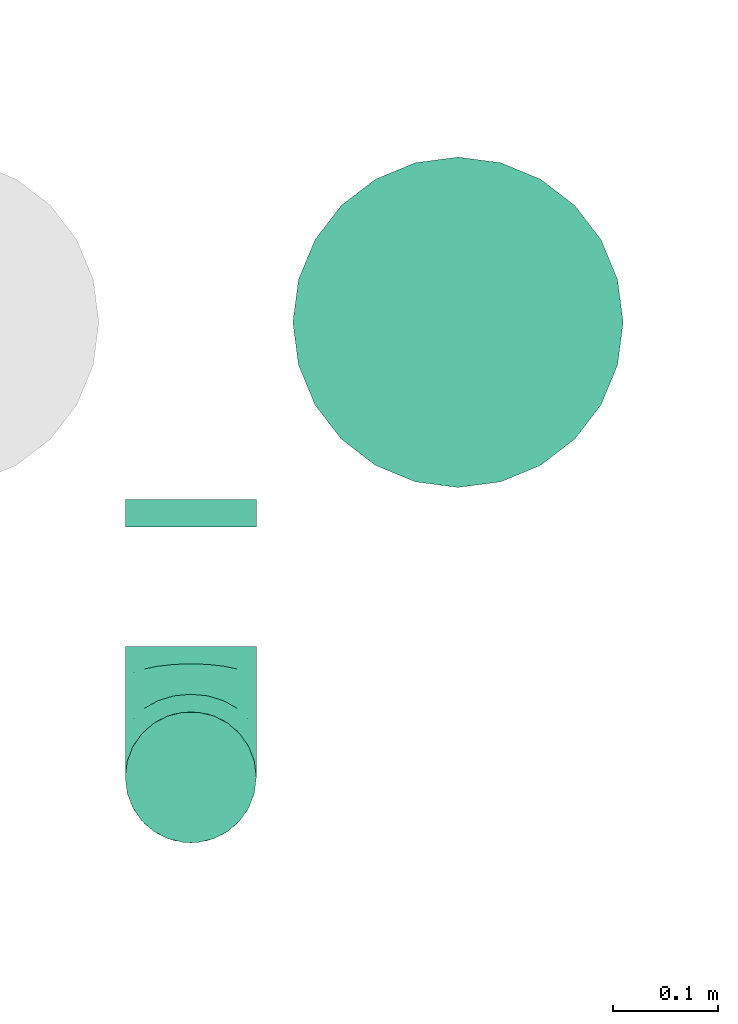
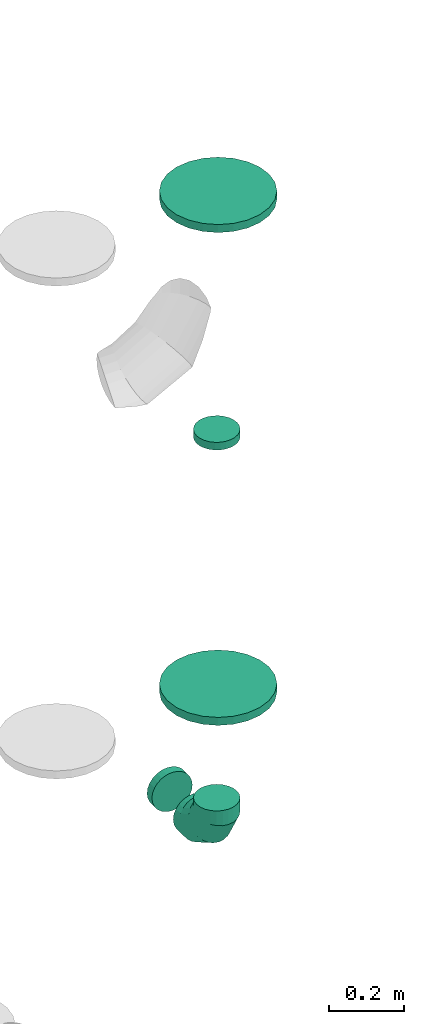
# One storey, part 49 of 59: 5 flow fittings.
"""IFC2X3 building model written with IfcOpenShell, lengths in millimetres."""

from ifc_helpers import new_model, entity, si_unit, converted_unit, derived_unit, direction, frame, origin, origin_2d_with_axis, place, context, subcontext, project, spatial, circle, extrude, faceted_brep, source, transform, mapped, material, type_object, type_shapes, element, save


model = new_model("IFC2X3")

# Units and contexts
model_context = context("Model", 3, precision=0.01, world=origin(), true_north=direction((6.12303176911189e-17, 1.0)))
body_context = subcontext(model_context, "Body", "Model", "MODEL_VIEW")
ifc_project = project(units=[si_unit("LENGTHUNIT", "METRE", prefix="MILLI"), si_unit("AREAUNIT", "SQUARE_METRE"), si_unit("VOLUMEUNIT", "CUBIC_METRE"), converted_unit("PLANEANGLEUNIT", "DEGREE", entity("IfcRatioMeasure", 0.0174532925199433), si_unit("PLANEANGLEUNIT", "RADIAN"), dimensions=[0, 0, 0, 0, 0, 0, 0]), si_unit("MASSUNIT", "GRAM", prefix="KILO"), derived_unit("MASSDENSITYUNIT", [(si_unit("MASSUNIT", "GRAM", prefix="KILO"), 1), (si_unit("LENGTHUNIT", "METRE"), -3)]), derived_unit("MOMENTOFINERTIAUNIT", [(si_unit("LENGTHUNIT", "METRE"), 4)]), si_unit("TIMEUNIT", "SECOND"), si_unit("FREQUENCYUNIT", "HERTZ"), si_unit("THERMODYNAMICTEMPERATUREUNIT", "DEGREE_CELSIUS"), derived_unit("THERMALTRANSMITTANCEUNIT", [(si_unit("MASSUNIT", "GRAM", prefix="KILO"), 1), (si_unit("THERMODYNAMICTEMPERATUREUNIT", "KELVIN"), -1), (si_unit("TIMEUNIT", "SECOND"), -3)]), derived_unit("VOLUMETRICFLOWRATEUNIT", [(si_unit("LENGTHUNIT", "METRE"), 3), (si_unit("TIMEUNIT", "SECOND"), -1)]), derived_unit("MASSFLOWRATEUNIT", [(si_unit("MASSUNIT", "GRAM", prefix="KILO"), 1), (si_unit("TIMEUNIT", "SECOND"), -1)]), derived_unit("ROTATIONALFREQUENCYUNIT", [(si_unit("TIMEUNIT", "SECOND"), -1)]), si_unit("ELECTRICCURRENTUNIT", "AMPERE"), si_unit("ELECTRICVOLTAGEUNIT", "VOLT"), si_unit("POWERUNIT", "WATT"), si_unit("FORCEUNIT", "NEWTON", prefix="KILO"), si_unit("ILLUMINANCEUNIT", "LUX"), si_unit("LUMINOUSFLUXUNIT", "LUMEN"), si_unit("LUMINOUSINTENSITYUNIT", "CANDELA"), derived_unit("USERDEFINED", [(si_unit("MASSUNIT", "GRAM", prefix="KILO"), -1), (si_unit("LENGTHUNIT", "METRE"), -2), (si_unit("TIMEUNIT", "SECOND"), 3), (si_unit("LUMINOUSFLUXUNIT", "LUMEN"), 1)]), derived_unit("LINEARVELOCITYUNIT", [(si_unit("LENGTHUNIT", "METRE"), 1), (si_unit("TIMEUNIT", "SECOND"), -1)]), si_unit("PRESSUREUNIT", "PASCAL"), derived_unit("USERDEFINED", [(si_unit("LENGTHUNIT", "METRE"), -2), (si_unit("MASSUNIT", "GRAM", prefix="KILO"), 1), (si_unit("TIMEUNIT", "SECOND"), -2)]), derived_unit("LINEARFORCEUNIT", [(si_unit("MASSUNIT", "GRAM", prefix="KILO"), 1), (si_unit("LENGTHUNIT", "METRE"), 1), (si_unit("TIMEUNIT", "SECOND"), -2), (si_unit("LENGTHUNIT", "METRE"), -1)]), derived_unit("PLANARFORCEUNIT", [(si_unit("MASSUNIT", "GRAM", prefix="KILO"), 1), (si_unit("LENGTHUNIT", "METRE"), 1), (si_unit("TIMEUNIT", "SECOND"), -2), (si_unit("LENGTHUNIT", "METRE"), -2)])], contexts=[model_context])

# Site, building, storey
site_placement = place(None, origin())
site = spatial("IfcSite", under=ifc_project, at=site_placement, CompositionType="ELEMENT")
building_placement = place(site_placement, origin())
building = spatial("IfcBuilding", under=site, at=building_placement, CompositionType="ELEMENT")
storey_placement = place(building_placement, frame((0.0, 0.0, 28200.0)))
storey = spatial("IfcBuildingStorey", under=building, at=storey_placement, CompositionType="ELEMENT", Elevation=28200.0)

# Flow fittings
ifc_material = material()
duct_fitting_type_1 = type_object("IfcDuctFittingType", PredefinedType="NOTDEFINED", material=ifc_material)
shared_shape_1 = source(origin(), body_context, "Body", "SweptSolid", [
    extrude(circle(Radius=62.4999999999996, at=origin_2d_with_axis()), frame((0.0, 0.0, 0.0), z_axis=(1.0, 0.0, 0.0), x_axis=(0.0, 1.0, 0.0)), (0.0, 0.0, 1.0), 25.0000000000018),
])
type_shapes(duct_fitting_type_1, [shared_shape_1])
flow_fitting_1_placement = place(storey_placement, frame((72718.06, 16207.74, 1705.0), z_axis=(0.0, 1.0, 0.0), x_axis=(0.0, 0.0, 1.0)))
element("IfcFlowFitting", 1, at=flow_fitting_1_placement, inside=storey, type_object=duct_fitting_type_1, material=ifc_material, context=body_context, shape_type="MappedRepresentation", body=[
    mapped(shared_shape_1, transform((0.0, 0.0, 0.0), scale=1.0)),
])
duct_fitting_type_2 = type_object("IfcDuctFittingType", PredefinedType="NOTDEFINED", material=ifc_material)
shared_shape_2 = source(origin(), body_context, "Body", "Brep", [
    faceted_brep([(-125.0, 0.0, -62.5), (-125.0, -16.18, -60.37), (-125.0, -31.25, -54.13), (-125.0, -44.19, -44.19), (-125.0, -54.13, -31.25), (-125.0, -60.37, -16.18), (-125.0, -62.5, 0.0), (-125.0, -60.37, 16.18), (-125.0, -54.13, 31.25), (-125.0, -44.19, 44.19), (-125.0, -31.25, 54.13), (-125.0, -16.18, 60.37), (-125.0, 0.0, 62.5), (-125.0, 16.18, 60.37), (-125.0, 31.25, 54.13), (-125.0, 44.19, 44.19), (-125.0, 54.13, 31.25), (-125.0, 60.37, 16.18), (-125.0, 62.5, 0.0), (-125.0, 60.37, -16.18), (-125.0, 54.13, -31.25), (-125.0, 44.19, -44.19), (-125.0, 31.25, -54.13), (-125.0, 16.18, -60.37), (-95.84, 16.18, 60.37), (-99.88, 31.25, 54.13), (-91.51, 0.0, 62.5), (-103.35, 44.19, 44.19), (-107.68, 60.37, 16.18), (-108.25, 62.5, 0.0), (-106.01, 54.13, 31.25), (-106.01, 54.13, -31.25), (-103.35, 44.19, -44.19), (-107.68, 60.37, -16.18), (-95.84, 16.18, -60.37), (-91.51, 0.0, -62.5), (-99.88, 31.25, -54.13), (-87.17, -16.18, -60.37), (-83.13, -31.25, -54.13), (-79.66, -44.19, -44.19), (-77.0, -54.13, -31.25), (-75.33, -60.37, -16.18), (-74.76, -62.5, 0.0), (-75.33, -60.37, 16.18), (-77.0, -54.13, 31.25), (-79.66, -44.19, 44.19), (-83.13, -31.25, 54.13), (-87.17, -16.18, 60.37), (-45.34, 45.34, 60.37), (-56.37, 56.37, 54.13), (-33.49, 33.49, 62.5), (-65.85, 65.85, 44.19), (-73.12, 73.12, 31.25), (-77.69, 77.69, 16.18), (-79.25, 79.25, 0.0), (-77.69, 77.69, -16.18), (-73.12, 73.12, -31.25), (-65.85, 65.85, -44.19), (-45.34, 45.34, -60.37), (-33.49, 33.49, -62.5), (-56.37, 56.37, -54.13), (-21.65, 21.65, -60.37), (-10.62, 10.62, -54.13), (-1.14, 1.14, -44.19), (6.13, -6.13, -31.25), (10.7, -10.7, -16.18), (12.26, -12.26, 0.0), (10.7, -10.7, 16.18), (6.13, -6.13, 31.25), (-1.14, 1.14, 44.19), (-10.62, 10.62, 54.13), (-21.65, 21.65, 60.37), (-16.18, 95.84, 60.37), (-31.25, 99.88, 54.13), (0.0, 91.51, 62.5), (-44.19, 103.35, 44.19), (-54.13, 106.01, 31.25), (-60.37, 107.68, 16.18), (-62.5, 108.25, 0.0), (-60.37, 107.68, -16.18), (-54.13, 106.01, -31.25), (-44.19, 103.35, -44.19), (-16.18, 95.84, -60.37), (0.0, 91.51, -62.5), (-31.25, 99.88, -54.13), (16.18, 87.17, -60.37), (31.25, 83.13, -54.13), (44.19, 79.66, -44.19), (54.13, 77.0, -31.25), (60.37, 75.33, -16.18), (62.5, 74.76, 0.0), (60.37, 75.33, 16.18), (54.13, 77.0, 31.25), (44.19, 79.66, 44.19), (31.25, 83.13, 54.13), (16.18, 87.17, 60.37), (-16.18, 125.0, -60.37), (-31.25, 125.0, -54.13), (-44.19, 125.0, -44.19), (-54.13, 125.0, -31.25), (-60.37, 125.0, -16.18), (-62.5, 125.0, 0.0), (-60.37, 125.0, 16.18), (-54.13, 125.0, 31.25), (-44.19, 125.0, 44.19), (-31.25, 125.0, 54.13), (-16.18, 125.0, 60.37), (0.0, 125.0, 62.5), (16.18, 125.0, 60.37), (31.25, 125.0, 54.13), (44.19, 125.0, 44.19), (54.13, 125.0, 31.25), (60.37, 125.0, 16.18), (62.5, 125.0, 0.0), (60.37, 125.0, -16.18), (54.13, 125.0, -31.25), (44.19, 125.0, -44.19), (31.25, 125.0, -54.13), (16.18, 125.0, -60.37), (0.0, 125.0, -62.5)], [[[0, 1, 2, 3, 4, 5, 6, 7, 8, 9, 10, 11, 12, 13, 14, 15, 16, 17, 18, 19, 20, 21, 22, 23]], [[24, 25, 14, 13]], [[26, 24, 13, 12]], [[14, 25, 27, 15]], [[28, 29, 18, 17]], [[30, 28, 17, 16]], [[15, 27, 30, 16]], [[20, 31, 32, 21]], [[33, 31, 20, 19]], [[18, 29, 33, 19]], [[34, 35, 0, 23]], [[36, 34, 23, 22]], [[21, 32, 36, 22]], [[1, 0, 35, 37]], [[2, 1, 37, 38]], [[38, 39, 3, 2]], [[5, 4, 40, 41]], [[6, 5, 41, 42]], [[39, 40, 4, 3]], [[6, 42, 43, 7]], [[7, 43, 44, 8]], [[45, 9, 8, 44]], [[9, 45, 46, 10]], [[10, 46, 47, 11]], [[26, 12, 11, 47]], [[48, 49, 25, 24]], [[50, 48, 24, 26]], [[27, 25, 49, 51]], [[52, 53, 28, 30]], [[51, 52, 30, 27]], [[29, 28, 53, 54]], [[55, 56, 31, 33]], [[54, 55, 33, 29]], [[57, 32, 31, 56]], [[58, 59, 35, 34]], [[60, 58, 34, 36]], [[57, 60, 36, 32]], [[37, 35, 59, 61]], [[38, 37, 61, 62]], [[39, 38, 62, 63]], [[41, 40, 64, 65]], [[42, 41, 65, 66]], [[63, 64, 40, 39]], [[43, 42, 66, 67]], [[44, 43, 67, 68]], [[68, 69, 45, 44]], [[46, 45, 69, 70]], [[47, 46, 70, 71]], [[26, 47, 71, 50]], [[72, 73, 49, 48]], [[74, 72, 48, 50]], [[51, 49, 73, 75]], [[76, 77, 53, 52]], [[75, 76, 52, 51]], [[54, 53, 77, 78]], [[79, 80, 56, 55]], [[78, 79, 55, 54]], [[81, 57, 56, 80]], [[82, 83, 59, 58]], [[84, 82, 58, 60]], [[81, 84, 60, 57]], [[61, 59, 83, 85]], [[62, 61, 85, 86]], [[63, 62, 86, 87]], [[65, 64, 88, 89]], [[66, 65, 89, 90]], [[87, 88, 64, 63]], [[67, 66, 90, 91]], [[68, 67, 91, 92]], [[92, 93, 69, 68]], [[70, 69, 93, 94]], [[71, 70, 94, 95]], [[50, 71, 95, 74]], [[96, 97, 98, 99, 100, 101, 102, 103, 104, 105, 106, 107, 108, 109, 110, 111, 112, 113, 114, 115, 116, 117, 118, 119]], [[72, 74, 107, 106]], [[73, 72, 106, 105]], [[75, 73, 105, 104]], [[77, 76, 103, 102]], [[78, 77, 102, 101]], [[75, 104, 103, 76]], [[78, 101, 100, 79]], [[79, 100, 99, 80]], [[80, 99, 98, 81]], [[96, 119, 83, 82]], [[97, 96, 82, 84]], [[84, 81, 98, 97]], [[83, 119, 118, 85]], [[85, 118, 117, 86]], [[116, 87, 86, 117]], [[88, 115, 114, 89]], [[89, 114, 113, 90]], [[115, 88, 87, 116]], [[91, 90, 113, 112]], [[92, 91, 112, 111]], [[111, 110, 93, 92]], [[95, 94, 109, 108]], [[74, 95, 108, 107]], [[110, 109, 94, 93]]]),
])
type_shapes(duct_fitting_type_2, [shared_shape_2])
flow_fitting_2_placement = place(storey_placement, frame((72718.06, 16207.74, 400.0), z_axis=(1.0, 0.0, 0.0), x_axis=(0.0, 0.0, -1.0)))
element("IfcFlowFitting", 2, at=flow_fitting_2_placement, inside=storey, type_object=duct_fitting_type_2, material=ifc_material, context=body_context, shape_type="MappedRepresentation", body=[
    mapped(shared_shape_2, transform((0.0, 0.0, 0.0), scale=1.0)),
])
duct_fitting_type_3 = type_object("IfcDuctFittingType", PredefinedType="NOTDEFINED", material=ifc_material)
shared_shape_3 = source(origin(), body_context, "Body", "Brep", [
    faceted_brep([(20.0, 0.0, -62.5), (20.0, 16.18, -60.37), (20.0, 31.25, -54.13), (20.0, 44.19, -44.19), (20.0, 54.13, -31.25), (20.0, 60.37, -16.18), (20.0, 62.5, 0.0), (20.0, 60.37, 16.18), (20.0, 54.13, 31.25), (20.0, 44.19, 44.19), (20.0, 31.25, 54.13), (20.0, 16.18, 60.37), (20.0, 0.0, 62.5), (20.0, -16.18, 60.37), (20.0, -31.25, 54.13), (20.0, -44.19, 44.19), (20.0, -54.13, 31.25), (20.0, -60.37, 16.18), (20.0, -62.5, 0.0), (20.0, -60.37, -16.18), (20.0, -54.13, -31.25), (20.0, -44.19, -44.19), (20.0, -31.25, -54.13), (20.0, -16.18, -60.37), (0.0, 0.0, 62.5), (-6.1, 0.0, 62.5), (-6.1, -16.18, 60.37), (0.0, -16.18, 60.37), (-6.1, -31.25, 54.13), (0.0, -31.25, 54.13), (0.0, -44.19, 44.19), (-6.1, -44.19, 44.19), (0.0, -54.13, 31.25), (-6.1, -54.13, 31.25), (-6.1, -60.37, 16.18), (0.0, -60.37, 16.18), (-6.1, -62.5, 0.0), (0.0, -62.5, 0.0), (-6.1, -60.37, -16.18), (0.0, -60.37, -16.18), (-6.1, -54.13, -31.25), (0.0, -54.13, -31.25), (0.0, -44.19, -44.19), (-6.1, -44.19, -44.19), (0.0, -31.25, -54.13), (-6.1, -31.25, -54.13), (-6.1, -16.18, -60.37), (0.0, -16.18, -60.37), (-6.1, 0.0, -62.5), (0.0, 0.0, -62.5), (-6.1, 16.18, -60.37), (0.0, 16.18, -60.37), (-6.1, 31.25, -54.13), (0.0, 31.25, -54.13), (0.0, 44.19, -44.19), (-6.1, 44.19, -44.19), (0.0, 54.13, -31.25), (-6.1, 54.13, -31.25), (-6.1, 60.37, -16.18), (0.0, 60.37, -16.18), (-6.1, 62.5, 0.0), (0.0, 62.5, 0.0), (-6.1, 60.37, 16.18), (0.0, 60.37, 16.18), (-6.1, 54.13, 31.25), (0.0, 54.13, 31.25), (0.0, 44.19, 44.19), (-6.1, 44.19, 44.19), (0.0, 31.25, 54.13), (-6.1, 31.25, 54.13), (-6.1, 16.18, 60.37), (0.0, 16.18, 60.37)], [[[0, 1, 2, 3, 4, 5, 6, 7, 8, 9, 10, 11, 12, 13, 14, 15, 16, 17, 18, 19, 20, 21, 22, 23]], [[13, 12, 24, 25, 26, 27]], [[14, 13, 27, 26, 28, 29]], [[30, 15, 14, 29, 28, 31]], [[17, 16, 32, 33, 34, 35]], [[18, 17, 35, 34, 36, 37]], [[32, 16, 15, 30, 31, 33]], [[19, 18, 37, 36, 38, 39]], [[20, 19, 39, 38, 40, 41]], [[42, 21, 20, 41, 40, 43]], [[23, 22, 44, 45, 46, 47]], [[0, 23, 47, 46, 48, 49]], [[44, 22, 21, 42, 43, 45]], [[1, 0, 49, 48, 50, 51]], [[2, 1, 51, 50, 52, 53]], [[54, 3, 2, 53, 52, 55]], [[5, 4, 56, 57, 58, 59]], [[6, 5, 59, 58, 60, 61]], [[56, 4, 3, 54, 55, 57]], [[7, 6, 61, 60, 62, 63]], [[8, 7, 63, 62, 64, 65]], [[66, 9, 8, 65, 64, 67]], [[11, 10, 68, 69, 70, 71]], [[12, 11, 71, 70, 25, 24]], [[68, 10, 9, 66, 67, 69]], [[46, 45, 43, 40, 38, 36, 34, 33, 31, 28, 26, 25, 70, 69, 67, 64, 62, 60, 58, 57, 55, 52, 50, 48]]]),
])
type_shapes(duct_fitting_type_3, [shared_shape_3])
flow_fitting_3_placement = place(storey_placement, frame((72718.06, 16466.7, 400.0), z_axis=(0.0, 0.0, -1.0), x_axis=(0.0, -1.0, 0.0)))
element("IfcFlowFitting", 3, at=flow_fitting_3_placement, inside=storey, type_object=duct_fitting_type_3, material=ifc_material, context=body_context, shape_type="MappedRepresentation", body=[
    mapped(shared_shape_3, transform((0.0, 0.0, 0.0), scale=1.0)),
])
duct_fitting_type_4 = type_object("IfcDuctFittingType", PredefinedType="NOTDEFINED", material=ifc_material)
shared_shape_4 = source(origin(), body_context, "Body", "Brep", [
    faceted_brep([(20.0, 40.76, -152.13), (20.0, 78.75, -136.4), (20.0, 111.37, -111.37), (20.0, 136.4, -78.75), (20.0, 152.13, -40.76), (20.0, 157.5, 0.0), (20.0, 152.13, 40.76), (20.0, 136.4, 78.75), (20.0, 111.37, 111.37), (20.0, 78.75, 136.4), (20.0, 40.76, 152.13), (20.0, 0.0, 157.5), (20.0, -40.76, 152.13), (20.0, -78.75, 136.4), (20.0, -111.37, 111.37), (20.0, -136.4, 78.75), (20.0, -152.13, 40.76), (20.0, -157.5, 0.0), (20.0, -152.13, -40.76), (20.0, -136.4, -78.75), (20.0, -111.37, -111.37), (20.0, -78.75, -136.4), (20.0, -40.76, -152.13), (20.0, 0.0, -157.5), (0.0, 0.0, 157.5), (0.0, 40.76, 152.13), (-6.1, 40.76, 152.13), (-6.1, 0.0, 157.5), (0.0, 78.75, 136.4), (-6.1, 78.75, 136.4), (0.0, 111.37, 111.37), (-6.1, 111.37, 111.37), (0.0, 136.4, 78.75), (0.0, 152.13, 40.76), (-6.1, 152.13, 40.76), (-6.1, 136.4, 78.75), (0.0, 157.5, 0.0), (-6.1, 157.5, 0.0), (0.0, 152.13, -40.76), (-6.1, 152.13, -40.76), (0.0, 136.4, -78.75), (-6.1, 136.4, -78.75), (0.0, 111.37, -111.37), (-6.1, 111.37, -111.37), (0.0, 0.0, -157.5), (-6.1, 0.0, -157.5), (-6.1, 40.76, -152.13), (0.0, 40.76, -152.13), (-6.1, 78.75, -136.4), (0.0, 78.75, -136.4), (0.0, -40.76, -152.13), (-6.1, -40.76, -152.13), (0.0, -78.75, -136.4), (-6.1, -78.75, -136.4), (0.0, -111.37, -111.37), (-6.1, -111.37, -111.37), (0.0, -136.4, -78.75), (0.0, -152.13, -40.76), (-6.1, -152.13, -40.76), (-6.1, -136.4, -78.75), (0.0, -157.5, 0.0), (-6.1, -157.5, 0.0), (0.0, -152.13, 40.76), (-6.1, -152.13, 40.76), (0.0, -136.4, 78.75), (-6.1, -136.4, 78.75), (0.0, -111.37, 111.37), (-6.1, -111.37, 111.37), (0.0, -78.75, 136.4), (0.0, -40.76, 152.13), (-6.1, -40.76, 152.13), (-6.1, -78.75, 136.4)], [[[0, 1, 2, 3, 4, 5, 6, 7, 8, 9, 10, 11, 12, 13, 14, 15, 16, 17, 18, 19, 20, 21, 22, 23]], [[24, 11, 10, 25, 26, 27]], [[25, 10, 9, 28, 29, 26]], [[28, 9, 8, 30, 31, 29]], [[32, 7, 6, 33, 34, 35]], [[33, 6, 5, 36, 37, 34]], [[30, 8, 7, 32, 35, 31]], [[36, 5, 4, 38, 39, 37]], [[38, 4, 3, 40, 41, 39]], [[40, 3, 2, 42, 43, 41]], [[0, 23, 44, 45, 46, 47]], [[1, 0, 47, 46, 48, 49]], [[49, 48, 43, 42, 2, 1]], [[44, 23, 22, 50, 51, 45]], [[50, 22, 21, 52, 53, 51]], [[52, 21, 20, 54, 55, 53]], [[56, 19, 18, 57, 58, 59]], [[57, 18, 17, 60, 61, 58]], [[54, 20, 19, 56, 59, 55]], [[60, 17, 16, 62, 63, 61]], [[62, 16, 15, 64, 65, 63]], [[64, 15, 14, 66, 67, 65]], [[68, 13, 12, 69, 70, 71]], [[69, 12, 11, 24, 27, 70]], [[66, 14, 13, 68, 71, 67]], [[45, 51, 53, 55, 59, 58, 61, 63, 65, 67, 71, 70, 27, 26, 29, 31, 35, 34, 37, 39, 41, 43, 48, 46]]]),
])
type_shapes(duct_fitting_type_4, [shared_shape_4])
flow_fitting_4_placement = place(storey_placement, frame((72972.91, 16641.7, 525.0), z_axis=(0.0, 1.0, 0.0), x_axis=(0.0, 0.0, 1.0)))
element("IfcFlowFitting", 4, at=flow_fitting_4_placement, inside=storey, type_object=duct_fitting_type_4, material=ifc_material, context=body_context, shape_type="MappedRepresentation", body=[
    mapped(shared_shape_4, transform((0.0, 0.0, 0.0), scale=1.0)),
])
duct_fitting_type_5 = type_object("IfcDuctFittingType", PredefinedType="NOTDEFINED", material=ifc_material)
shared_shape_5 = source(origin(), body_context, "Body", "Brep", [
    faceted_brep([(20.0, 0.0, -157.5), (20.0, 40.76, -152.13), (20.0, 78.75, -136.4), (20.0, 111.37, -111.37), (20.0, 136.4, -78.75), (20.0, 152.13, -40.76), (20.0, 157.5, 0.0), (20.0, 152.13, 40.76), (20.0, 136.4, 78.75), (20.0, 111.37, 111.37), (20.0, 78.75, 136.4), (20.0, 40.76, 152.13), (20.0, 0.0, 157.5), (20.0, -40.76, 152.13), (20.0, -78.75, 136.4), (20.0, -111.37, 111.37), (20.0, -136.4, 78.75), (20.0, -152.13, 40.76), (20.0, -157.5, 0.0), (20.0, -152.13, -40.76), (20.0, -136.4, -78.75), (20.0, -111.37, -111.37), (20.0, -78.75, -136.4), (20.0, -40.76, -152.13), (0.0, 0.0, 157.5), (-6.1, 0.0, 157.5), (-6.1, -40.76, 152.13), (0.0, -40.76, 152.13), (-6.1, -78.75, 136.4), (0.0, -78.75, 136.4), (0.0, -111.37, 111.37), (-6.1, -111.37, 111.37), (0.0, -136.4, 78.75), (-6.1, -136.4, 78.75), (-6.1, -152.13, 40.76), (0.0, -152.13, 40.76), (-6.1, -157.5, 0.0), (0.0, -157.5, 0.0), (-6.1, -152.13, -40.76), (0.0, -152.13, -40.76), (-6.1, -136.4, -78.75), (0.0, -136.4, -78.75), (0.0, -111.37, -111.37), (-6.1, -111.37, -111.37), (0.0, 0.0, -157.5), (0.0, -40.76, -152.13), (-6.1, -40.76, -152.13), (-6.1, 0.0, -157.5), (0.0, -78.75, -136.4), (-6.1, -78.75, -136.4), (-6.1, 40.76, -152.13), (0.0, 40.76, -152.13), (-6.1, 78.75, -136.4), (0.0, 78.75, -136.4), (0.0, 111.37, -111.37), (-6.1, 111.37, -111.37), (0.0, 136.4, -78.75), (-6.1, 136.4, -78.75), (-6.1, 152.13, -40.76), (0.0, 152.13, -40.76), (-6.1, 157.5, 0.0), (0.0, 157.5, 0.0), (-6.1, 152.13, 40.76), (0.0, 152.13, 40.76), (-6.1, 136.4, 78.75), (0.0, 136.4, 78.75), (0.0, 111.37, 111.37), (-6.1, 111.37, 111.37), (0.0, 78.75, 136.4), (-6.1, 78.75, 136.4), (-6.1, 40.76, 152.13), (0.0, 40.76, 152.13)], [[[0, 1, 2, 3, 4, 5, 6, 7, 8, 9, 10, 11, 12, 13, 14, 15, 16, 17, 18, 19, 20, 21, 22, 23]], [[13, 12, 24, 25, 26, 27]], [[14, 13, 27, 26, 28, 29]], [[30, 15, 14, 29, 28, 31]], [[17, 16, 32, 33, 34, 35]], [[18, 17, 35, 34, 36, 37]], [[32, 16, 15, 30, 31, 33]], [[19, 18, 37, 36, 38, 39]], [[20, 19, 39, 38, 40, 41]], [[42, 21, 20, 41, 40, 43]], [[44, 0, 23, 45, 46, 47]], [[48, 49, 46, 45, 23, 22]], [[22, 21, 42, 43, 49, 48]], [[1, 0, 44, 47, 50, 51]], [[2, 1, 51, 50, 52, 53]], [[54, 3, 2, 53, 52, 55]], [[5, 4, 56, 57, 58, 59]], [[6, 5, 59, 58, 60, 61]], [[56, 4, 3, 54, 55, 57]], [[7, 6, 61, 60, 62, 63]], [[8, 7, 63, 62, 64, 65]], [[66, 9, 8, 65, 64, 67]], [[11, 10, 68, 69, 70, 71]], [[12, 11, 71, 70, 25, 24]], [[68, 10, 9, 66, 67, 69]], [[46, 49, 43, 40, 38, 36, 34, 33, 31, 28, 26, 25, 70, 69, 67, 64, 62, 60, 58, 57, 55, 52, 50, 47]]]),
])
type_shapes(duct_fitting_type_5, [shared_shape_5])
flow_fitting_5_placement = place(storey_placement, frame((72972.91, 16641.7, 2150.0), z_axis=(0.0, 1.0, 0.0), x_axis=(0.0, 0.0, -1.0)))
element("IfcFlowFitting", 5, at=flow_fitting_5_placement, inside=storey, type_object=duct_fitting_type_5, material=ifc_material, context=body_context, shape_type="MappedRepresentation", body=[
    mapped(shared_shape_5, transform((0.0, 0.0, 0.0), scale=1.0)),
])

save(model, "model.ifc")
